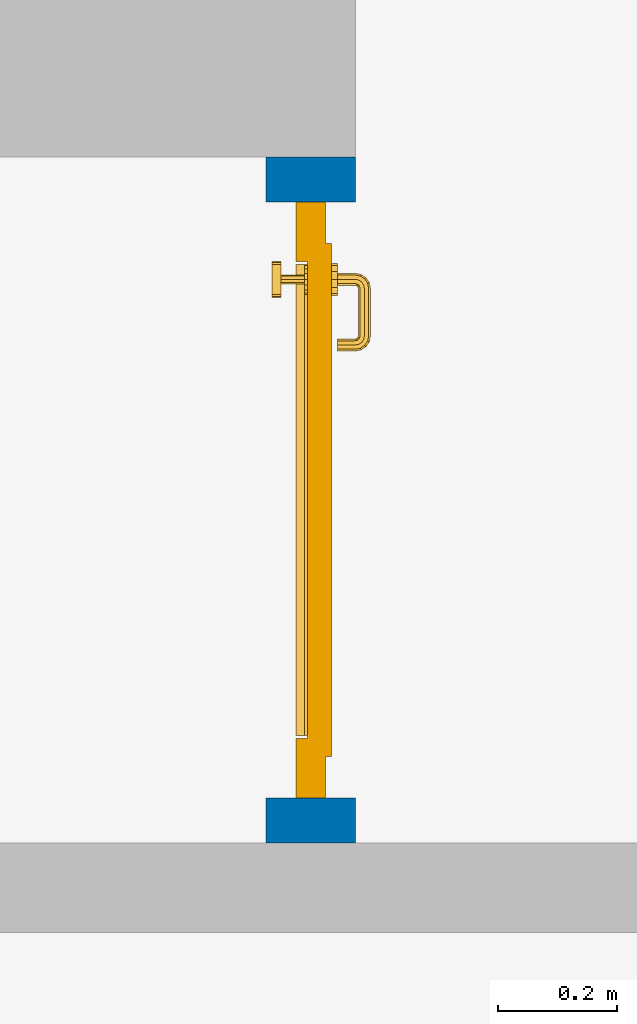
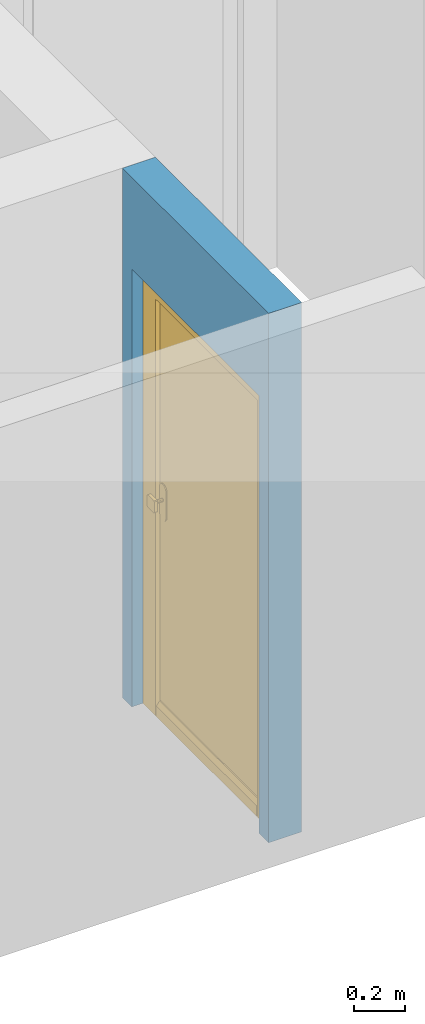
# One storey, part 4 of 54: 1 door, 1 wall, 1 opening.
"""IFC4 building model written with IfcOpenShell, lengths in metres."""

from ifc_helpers import new_model, entity, si_unit, converted_unit, derived_unit, direction, frame, origin_with_axes, place, context, subcontext, project, spatial, polygons, source, transform, mapped, material, type_object, element, fill, save


model = new_model("IFC4")

# Units and contexts
model_context = context("Model", 3, precision=1e-05, world=origin_with_axes(), true_north=direction((0.0, 1.0)))
body_context = subcontext(model_context, "Body", "Model", "MODEL_VIEW")
ifc_project = project(units=[si_unit("LENGTHUNIT", "METRE"), si_unit("AREAUNIT", "SQUARE_METRE"), si_unit("VOLUMEUNIT", "CUBIC_METRE"), converted_unit("PLANEANGLEUNIT", "DEGREE", entity("IfcPlaneAngleMeasure", 0.0174532925199), si_unit("PLANEANGLEUNIT", "RADIAN"), dimensions=[0, 0, 0, 0, 0, 0, 0]), converted_unit("TIMEUNIT", "Year", entity("IfcTimeMeasure", 31556926.0), si_unit("TIMEUNIT", "SECOND"), dimensions=[0, 0, 1, 0, 0, 0, 0]), si_unit("MASSUNIT", "GRAM", prefix="KILO"), si_unit("THERMODYNAMICTEMPERATUREUNIT", "DEGREE_CELSIUS"), si_unit("LUMINOUSINTENSITYUNIT", "LUMEN"), si_unit("ENERGYUNIT", "JOULE", prefix="MEGA"), derived_unit("THERMALCONDUCTANCEUNIT", [(si_unit("POWERUNIT", "WATT"), 1), (si_unit("LENGTHUNIT", "METRE"), -1), (si_unit("THERMODYNAMICTEMPERATUREUNIT", "KELVIN"), -1)]), derived_unit("SPECIFICHEATCAPACITYUNIT", [(si_unit("ENERGYUNIT", "JOULE"), 1), (si_unit("MASSUNIT", "GRAM", prefix="KILO"), -1), (si_unit("THERMODYNAMICTEMPERATUREUNIT", "KELVIN"), -1)]), derived_unit("MASSDENSITYUNIT", [(si_unit("MASSUNIT", "GRAM", prefix="KILO"), 1), (si_unit("VOLUMEUNIT", "CUBIC_METRE"), -1)])], contexts=[model_context])

# Site, building, storey
site_placement = place(None, origin_with_axes())
site = spatial("IfcSite", under=ifc_project, at=site_placement, CompositionType="ELEMENT")
building_placement = place(site_placement, origin_with_axes())
building = spatial("IfcBuilding", under=site, at=building_placement, CompositionType="ELEMENT")
storey_placement = place(building_placement, frame((0.0, 0.0, 6.29), z_axis=(0.0, 0.0, 1.0), x_axis=(1.0, 0.0, 0.0)))
storey = spatial("IfcBuildingStorey", under=building, at=storey_placement, Name="2. Geschoss", CompositionType="ELEMENT", Elevation=6.29)

# Wall, opening, door
ifc_material = material()
wall_type = type_object("IfcWallType", Name="150", PredefinedType="NOTDEFINED")
wall_placement = place(storey_placement, frame((2.8378006196, -4.12881223104, 0.0), z_axis=(0.0, 0.0, 1.0), x_axis=(0.0, 1.0, 0.0)))
wall = element("IfcWall", 1, at=wall_placement, inside=storey, type_object=wall_type, material=ifc_material, Name="Wand-002", PredefinedType="NOTDEFINED", context=body_context, shape_type="Tessellation", body=[
    polygons([(0.225, 0.0, 0.0), (0.225, 0.0, 2.1), (1.225, 0.0, 2.1), (1.225, 0.0, 0.0), (1.3, 0.0, 0.0), (1.3, 0.0, 2.54), (0.15, 0.0, 2.54), (0.15, 0.0, 0.0), (0.225, 0.1, 0.0), (0.225, 0.15, 0.0), (0.225, 0.15, 2.1), (1.225, 0.15, 2.1), (1.225, 0.1, 0.0), (1.225, 0.15, 0.0), (1.3, 0.15, 0.0), (1.3, 0.15, 2.54), (0.15, 0.15, 2.54), (0.15, 0.15, 0.0)], [[[1, 2, 3, 4, 5, 6, 7, 8]], [[2, 1, 9, 10, 11]], [[3, 2, 11, 12]], [[13, 4, 3, 12, 14]], [[4, 13, 14, 15, 5]], [[6, 5, 15, 16]], [[6, 16, 17, 7]], [[17, 18, 8, 7]], [[9, 1, 8, 18, 10]], [[15, 14, 12, 11, 10, 18, 17, 16]]], closed=True),
])
opening_placement = place(wall_placement, frame((0.725, 0.0, 0.0), z_axis=(0.0, 0.0, 1.0), x_axis=(1.0, 0.0, 0.0)))
opening = element("IfcOpeningElement", 2, at=opening_placement, cuts=wall, context=body_context, identifier="Reference", shape_type="Tessellation", body=[
    polygons([(-0.5, 0.1, 0.0), (-0.5, 0.1, 2.1), (-0.5, 0.151, 2.1), (-0.5, 0.151, 0.0), (-0.5, -0.001, 0.0), (-0.5, -0.001, 2.1), (0.5, 0.1, 2.1), (0.5, 0.151, 2.1), (0.5, -0.001, 2.1), (0.5, 0.151, 0.0), (0.5, 0.1, 0.0), (0.5, -0.001, 0.0)], [[[1, 2, 3, 4]], [[2, 1, 5, 6]], [[7, 8, 3, 2, 6, 9]], [[8, 10, 4, 3]], [[1, 4, 10, 11, 12, 5]], [[6, 5, 12, 9]], [[7, 11, 10, 8]], [[11, 7, 9, 12]]], closed=True),
])
door_type = type_object("IfcDoorType", Name="Eingang 01 1-Fl 26", OperationType="SINGLE_SWING_RIGHT", PredefinedType="DOOR")
shared_shape = source(origin_with_axes(), body_context, "Body", "Tessellation", [
    polygons([(0.5, -0.05, 0.0), (0.5, -0.03, 0.0), (0.5, -0.03, 2.1), (0.5, -0.05, 2.1), (0.4, -0.05, 0.0), (0.4, -0.03, 0.0), (0.4, -0.03, 2.0), (0.1301, -0.03, 2.0), (0.0001, -0.03, 2.0), (-0.4, -0.03, 2.0), (-0.4, -0.03, 0.0), (-0.5, -0.03, 0.0), (-0.5, -0.03, 2.1), (-0.5, -0.05, 2.1), (-0.5, -0.05, 0.0), (-0.4, -0.05, 0.0), (-0.4, -0.05, 2.0), (0.0001, -0.05, 2.0), (0.1301, -0.05, 2.0), (0.4, -0.05, 2.0)], [[[1, 2, 3, 4]], [[5, 6, 2, 1]], [[2, 6, 7, 8, 9, 10, 11, 12, 13, 3]], [[4, 3, 13, 14]], [[1, 4, 14, 15, 16, 17, 18, 19, 20, 5]], [[20, 7, 6, 5]], [[19, 8, 7, 20]], [[18, 9, 8, 19]], [[17, 10, 9, 18]], [[16, 11, 10, 17]], [[15, 12, 11, 16]], [[14, 13, 12, 15]]], closed=True),
    polygons([(0.5, -0.03, 0.0), (0.5, 0.0, 0.0), (0.5, 0.0, 2.1), (0.5, -0.03, 2.1), (0.43, -0.03, 0.0), (0.43, 0.0, 0.0), (0.43, 0.0, 2.03), (0.1001, 0.0, 2.03), (0.0301, 0.0, 2.03), (-0.43, 0.0, 2.03), (-0.43, 0.0, 0.0), (-0.5, 0.0, 0.0), (-0.5, 0.0, 2.1), (-0.5, -0.03, 2.1), (-0.5, -0.03, 0.0), (-0.43, -0.03, 0.0), (-0.43, -0.03, 2.03), (0.0301, -0.03, 2.03), (0.1001, -0.03, 2.03), (0.43, -0.03, 2.03)], [[[1, 2, 3, 4]], [[5, 6, 2, 1]], [[2, 6, 7, 8, 9, 10, 11, 12, 13, 3]], [[4, 3, 13, 14]], [[1, 4, 14, 15, 16, 17, 18, 19, 20, 5]], [[20, 7, 6, 5]], [[19, 8, 7, 20]], [[18, 9, 8, 19]], [[17, 10, 9, 18]], [[16, 11, 10, 17]], [[15, 12, 11, 16]], [[14, 13, 12, 15]]], closed=True),
    polygons([(0.43, 0.01, 0.0), (-0.43, 0.01, 0.0), (-0.43, 0.01, 2.03), (0.43, 0.01, 2.03), (0.43, -0.03, 0.0), (-0.43, -0.03, 0.0), (-0.43, -0.03, 2.03), (0.43, -0.03, 2.03)], [[[1, 2, 3, 4]], [[2, 1, 5, 6]], [[3, 2, 6, 7]], [[4, 3, 7, 8]], [[1, 4, 8, 5]], [[6, 5, 8, 7]]], closed=True),
    polygons([(0.395, -0.05, 0.0), (0.395, -0.05, 0.05), (-0.395, -0.05, 0.05), (-0.395, -0.05, 0.0), (0.395, -0.03, 0.0), (0.395, -0.03, 0.07), (0.395, -0.035, 0.07), (-0.395, -0.035, 0.07), (-0.395, -0.03, 0.07), (-0.395, -0.03, 0.0)], [[[1, 2, 3, 4]], [[1, 5, 6, 7, 2]], [[2, 7, 8, 3]], [[4, 3, 8, 9, 10]], [[5, 1, 4, 10]], [[6, 5, 10, 9]], [[7, 6, 9, 8]]], closed=True),
    polygons([(-0.3835, 0.02, 1.0733826859), (-0.3835, 0.0199, 1.0733826859), (-0.37, 0.0199, 1.077), (-0.37, 0.02, 1.077), (-0.393382685902, 0.02, 1.0635), (-0.393382685902, 0.0199, 1.0635), (-0.3835, 0.0101, 1.0733826859), (-0.37, 0.0101, 1.077), (-0.3565, 0.0199, 1.0733826859), (-0.3565, 0.02, 1.0733826859), (-0.346617314098, 0.02, 1.0635), (-0.343, 0.02, 1.05), (-0.346617314098, 0.02, 1.0365), (-0.3565, 0.02, 1.0266173141), (-0.37, 0.02, 1.023), (-0.3835, 0.02, 1.0266173141), (-0.393382685902, 0.02, 1.0365), (-0.397, 0.02, 1.05), (-0.397, 0.0199, 1.05), (-0.393382685902, 0.0101, 1.0635), (-0.3835, 0.01, 1.0733826859), (-0.37, 0.01, 1.077), (-0.3565, 0.0101, 1.0733826859), (-0.346617314098, 0.0199, 1.0635), (-0.343, 0.0199, 1.05), (-0.346617314098, 0.0199, 1.0365), (-0.3565, 0.0199, 1.0266173141), (-0.37, 0.0199, 1.023), (-0.3835, 0.0199, 1.0266173141), (-0.393382685902, 0.0199, 1.0365), (-0.397, 0.0101, 1.05), (-0.393382685902, 0.01, 1.0635), (-0.397, 0.01, 1.05), (-0.393382685902, 0.01, 1.0365), (-0.3835, 0.01, 1.0266173141), (-0.37, 0.01, 1.023), (-0.3565, 0.01, 1.0266173141), (-0.346617314098, 0.01, 1.0365), (-0.343, 0.01, 1.05), (-0.346617314098, 0.01, 1.0635), (-0.3565, 0.01, 1.0733826859), (-0.346617314098, 0.0101, 1.0635), (-0.343, 0.0101, 1.05), (-0.346617314098, 0.0101, 1.0365), (-0.3565, 0.0101, 1.0266173141), (-0.37, 0.0101, 1.023), (-0.3835, 0.0101, 1.0266173141), (-0.393382685902, 0.0101, 1.0365)], [[[1, 2, 3, 4]], [[5, 6, 2, 1]], [[2, 7, 8, 3]], [[4, 3, 9, 10]], [[4, 10, 11, 12, 13, 14, 15, 16, 17, 18, 5, 1]], [[18, 19, 6, 5]], [[6, 20, 7, 2]], [[7, 21, 22, 8]], [[3, 8, 23, 9]], [[10, 9, 24, 11]], [[11, 24, 25, 12]], [[12, 25, 26, 13]], [[13, 26, 27, 14]], [[14, 27, 28, 15]], [[15, 28, 29, 16]], [[16, 29, 30, 17]], [[17, 30, 19, 18]], [[19, 31, 20, 6]], [[20, 32, 21, 7]], [[22, 21, 32, 33, 34, 35, 36, 37, 38, 39, 40, 41]], [[8, 22, 41, 23]], [[9, 23, 42, 24]], [[24, 42, 43, 25]], [[25, 43, 44, 26]], [[26, 44, 45, 27]], [[27, 45, 46, 28]], [[28, 46, 47, 29]], [[29, 47, 48, 30]], [[30, 48, 31, 19]], [[31, 33, 32, 20]], [[48, 34, 33, 31]], [[47, 35, 34, 48]], [[46, 36, 35, 47]], [[45, 37, 36, 46]], [[44, 38, 37, 45]], [[43, 39, 38, 44]], [[42, 40, 39, 43]], [[23, 41, 40, 42]]], closed=True),
    polygons([(-0.362532169224, 0.019, 0.959692280177), (-0.365, 0.019, 0.9544), (-0.365, 0.019, 0.952886751346), (-0.347569942042, 0.019, 0.96295), (-0.35705, 0.019, 0.972430057958), (-0.363279754556, 0.019, 0.961639806549), (-0.362532169224, 0.02, 0.959692280177), (-0.365, 0.02, 0.9544), (-0.365, 0.02, 0.952886751346), (-0.365, 0.02, 0.95), (-0.365, 0.02, 0.947113248654), (-0.365, 0.02, 0.941339745962), (-0.365, 0.02, 0.9375), (-0.365, 0.019, 0.9375), (-0.365, 0.019, 0.941339745962), (-0.365, 0.019, 0.947113248654), (-0.365, 0.019, 0.95), (-0.3441, 0.019, 0.95), (-0.347483339502, 0.019, 0.963), (-0.357, 0.019, 0.972516660498), (-0.364624817685, 0.019, 0.965143815798), (-0.37, 0.019, 0.9759), (-0.37, 0.019, 0.967425445323), (-0.364624817685, 0.02, 0.965143815798), (-0.363279754556, 0.02, 0.961639806549), (-0.35655, 0.02, 0.973296083362), (-0.346703916638, 0.02, 0.96345), (-0.3431, 0.02, 0.95), (-0.346703916638, 0.02, 0.93655), (-0.35655, 0.02, 0.926703916638), (-0.37, 0.02, 0.9231), (-0.37, 0.02, 0.9325), (-0.366464466094, 0.02, 0.933964466094), (-0.366464466094, 0.019, 0.933964466094), (-0.35705, 0.019, 0.927569942042), (-0.37, 0.019, 0.9325), (-0.37, 0.019, 0.9241), (-0.347569942042, 0.019, 0.93705), (-0.344, 0.019, 0.95), (-0.347483339502, 0.0189, 0.963), (-0.357, 0.0189, 0.972516660498), (-0.37, 0.019, 0.976), (-0.375375182315, 0.019, 0.965143815798), (-0.38295, 0.019, 0.972430057958), (-0.376720245444, 0.019, 0.961639806549), (-0.37, 0.02, 0.967425445323), (-0.37, 0.02, 0.9769), (-0.346617314098, 0.02, 0.9635), (-0.3565, 0.02, 0.973382685902), (-0.343, 0.02, 0.95), (-0.346617314098, 0.02, 0.9365), (-0.3565, 0.02, 0.926617314098), (-0.38345, 0.02, 0.926703916638), (-0.375, 0.02, 0.941339745962), (-0.375, 0.02, 0.9375), (-0.373535533906, 0.02, 0.933964466094), (-0.37, 0.02, 0.923), (-0.373535533906, 0.019, 0.933964466094), (-0.375, 0.019, 0.9375), (-0.375, 0.019, 0.941339745962), (-0.38295, 0.019, 0.927569942042), (-0.37, 0.019, 0.924), (-0.357, 0.019, 0.927483339502), (-0.347483339502, 0.019, 0.937), (-0.344, 0.0189, 0.95), (-0.347483339502, 0.0101, 0.963), (-0.357, 0.0101, 0.972516660498), (-0.37, 0.0189, 0.976), (-0.383, 0.019, 0.972516660498), (-0.375375182315, 0.02, 0.965143815798), (-0.377467830776, 0.019, 0.959692280177), (-0.392430057958, 0.019, 0.96295), (-0.375, 0.019, 0.952886751346), (-0.375, 0.019, 0.9544), (-0.377467830776, 0.02, 0.959692280177), (-0.376720245444, 0.02, 0.961639806549), (-0.38345, 0.02, 0.973296083362), (-0.37, 0.02, 0.977), (-0.346617314098, 0.0199, 0.9635), (-0.3565, 0.0199, 0.973382685902), (-0.343, 0.0199, 0.95), (-0.346617314098, 0.0199, 0.9365), (-0.3565, 0.0199, 0.926617314098), (-0.393296083362, 0.02, 0.93655), (-0.375, 0.02, 0.947113248654), (-0.375, 0.02, 0.9544), (-0.375, 0.019, 0.95), (-0.375, 0.019, 0.947113248654), (-0.375, 0.02, 0.95), (-0.375, 0.02, 0.952886751346), (-0.3835, 0.02, 0.926617314098), (-0.37, 0.0199, 0.923), (-0.392430057958, 0.019, 0.93705), (-0.383, 0.019, 0.927483339502), (-0.37, 0.0189, 0.924), (-0.357, 0.0189, 0.927483339502), (-0.347483339502, 0.0189, 0.937), (-0.344, 0.0101, 0.95), (-0.347483339502, 0.01, 0.963), (-0.357, 0.01, 0.972516660498), (-0.37, 0.0101, 0.976), (-0.383, 0.0189, 0.972516660498), (-0.392516660498, 0.019, 0.963), (-0.3959, 0.019, 0.95), (-0.393296083362, 0.02, 0.96345), (-0.3835, 0.02, 0.973382685902), (-0.37, 0.0199, 0.977), (-0.346617314098, 0.0101, 0.9635), (-0.3565, 0.0101, 0.973382685902), (-0.343, 0.0101, 0.95), (-0.346617314098, 0.0101, 0.9365), (-0.3565, 0.0101, 0.926617314098), (-0.393382685902, 0.02, 0.9365), (-0.3969, 0.02, 0.95), (-0.3835, 0.0199, 0.926617314098), (-0.37, 0.0101, 0.923), (-0.392516660498, 0.019, 0.937), (-0.383, 0.0189, 0.927483339502), (-0.37, 0.0101, 0.924), (-0.357, 0.0101, 0.927483339502), (-0.347483339502, 0.0101, 0.937), (-0.344, 0.01, 0.95), (-0.347396736961, 0.01, 0.96305), (-0.35695, 0.01, 0.972603263039), (-0.37, 0.01, 0.976), (-0.383, 0.0101, 0.972516660498), (-0.392516660498, 0.0189, 0.963), (-0.396, 0.019, 0.95), (-0.393382685902, 0.02, 0.9635), (-0.3835, 0.0199, 0.973382685902), (-0.37, 0.0101, 0.977), (-0.346617314098, 0.01, 0.9635), (-0.3565, 0.01, 0.973382685902), (-0.343, 0.01, 0.95), (-0.346617314098, 0.01, 0.9365), (-0.3565, 0.01, 0.926617314098), (-0.397, 0.02, 0.95), (-0.393382685902, 0.0199, 0.9365), (-0.3835, 0.0101, 0.926617314098), (-0.37, 0.01, 0.923), (-0.392516660498, 0.0189, 0.937), (-0.383, 0.0101, 0.927483339502), (-0.37, 0.01, 0.924), (-0.357, 0.01, 0.927483339502), (-0.347483339502, 0.01, 0.937), (-0.3439, 0.01, 0.95), (-0.346703916638, 0.01, 0.96345), (-0.35655, 0.01, 0.973296083362), (-0.37, 0.01, 0.9761), (-0.383, 0.01, 0.972516660498), (-0.392516660498, 0.0101, 0.963), (-0.396, 0.0189, 0.95), (-0.393382685902, 0.0199, 0.9635), (-0.3835, 0.0101, 0.973382685902), (-0.37, 0.01, 0.977), (-0.3431, 0.01, 0.95), (-0.346703916638, 0.01, 0.93655), (-0.35655, 0.01, 0.926703916638), (-0.397, 0.0199, 0.95), (-0.393382685902, 0.0101, 0.9365), (-0.3835, 0.01, 0.926617314098), (-0.37, 0.01, 0.9231), (-0.392516660498, 0.0101, 0.937), (-0.383, 0.01, 0.927483339502), (-0.37, 0.01, 0.9239), (-0.35695, 0.01, 0.927396736961), (-0.347396736961, 0.01, 0.93695), (-0.37, 0.01, 0.9769), (-0.38305, 0.01, 0.972603263039), (-0.392516660498, 0.01, 0.963), (-0.396, 0.0101, 0.95), (-0.393382685902, 0.0101, 0.9635), (-0.3835, 0.01, 0.973382685902), (-0.397, 0.0101, 0.95), (-0.393382685902, 0.01, 0.9365), (-0.38345, 0.01, 0.926703916638), (-0.392516660498, 0.01, 0.937), (-0.38305, 0.01, 0.927396736961), (-0.38345, 0.01, 0.973296083362), (-0.392603263039, 0.01, 0.96305), (-0.396, 0.01, 0.95), (-0.393382685902, 0.01, 0.9635), (-0.397, 0.01, 0.95), (-0.393296083362, 0.01, 0.93655), (-0.392603263039, 0.01, 0.93695), (-0.393296083362, 0.01, 0.96345), (-0.3961, 0.01, 0.95), (-0.3969, 0.01, 0.95)], [[[1, 2, 3, 4, 5, 6]], [[2, 1, 7, 8]], [[2, 8, 9, 10, 11, 12, 13, 14, 15, 16, 17, 3]], [[17, 18, 4, 3]], [[4, 19, 20, 5]], [[21, 6, 5, 22, 23]], [[1, 6, 21, 24, 25, 7]], [[7, 25, 26, 27, 9, 8]], [[9, 27, 28, 10]], [[10, 28, 29, 11]], [[11, 29, 30, 12]], [[31, 32, 33, 13, 12, 30]], [[14, 13, 33, 34]], [[35, 15, 14, 34, 36, 37]], [[15, 35, 38, 16]], [[16, 38, 18, 17]], [[18, 39, 19, 4]], [[19, 40, 41, 20]], [[5, 20, 42, 22]], [[43, 23, 22, 44, 45]], [[21, 23, 46, 24]], [[24, 46, 47, 26, 25]], [[48, 27, 26, 49]], [[50, 28, 27, 48]], [[51, 29, 28, 50]], [[52, 30, 29, 51]], [[53, 54, 55, 56, 32, 31]], [[34, 33, 32, 36]], [[57, 31, 30, 52]], [[37, 36, 58, 59, 60, 61]], [[37, 62, 63, 35]], [[35, 63, 64, 38]], [[38, 64, 39, 18]], [[39, 65, 40, 19]], [[40, 66, 67, 41]], [[20, 41, 68, 42]], [[22, 42, 69, 44]], [[23, 43, 70, 46]], [[71, 45, 44, 72, 73, 74]], [[43, 45, 71, 75, 76, 70]], [[70, 76, 77, 47, 46]], [[49, 26, 47, 78]], [[79, 48, 49, 80]], [[81, 50, 48, 79]], [[82, 51, 50, 81]], [[83, 52, 51, 82]], [[54, 53, 84, 85]], [[86, 74, 73, 87, 88, 60, 59, 55, 54, 85, 89, 90]], [[58, 56, 55, 59]], [[36, 32, 56, 58]], [[91, 53, 31, 57]], [[92, 57, 52, 83]], [[88, 93, 61, 60]], [[61, 94, 62, 37]], [[62, 95, 96, 63]], [[63, 96, 97, 64]], [[64, 97, 65, 39]], [[65, 98, 66, 40]], [[66, 99, 100, 67]], [[41, 67, 101, 68]], [[42, 68, 102, 69]], [[44, 69, 103, 72]], [[73, 72, 104, 87]], [[71, 74, 86, 75]], [[75, 86, 90, 105, 77, 76]], [[78, 47, 77, 106]], [[80, 49, 78, 107]], [[108, 79, 80, 109]], [[110, 81, 79, 108]], [[111, 82, 81, 110]], [[112, 83, 82, 111]], [[113, 84, 53, 91]], [[85, 84, 114, 89]], [[87, 104, 93, 88]], [[89, 114, 105, 90]], [[115, 91, 57, 92]], [[116, 92, 83, 112]], [[93, 117, 94, 61]], [[94, 118, 95, 62]], [[95, 119, 120, 96]], [[96, 120, 121, 97]], [[97, 121, 98, 65]], [[98, 122, 99, 66]], [[99, 123, 124, 100]], [[67, 100, 125, 101]], [[68, 101, 126, 102]], [[69, 102, 127, 103]], [[72, 103, 128, 104]], [[106, 77, 105, 129]], [[107, 78, 106, 130]], [[109, 80, 107, 131]], [[132, 108, 109, 133]], [[134, 110, 108, 132]], [[135, 111, 110, 134]], [[136, 112, 111, 135]], [[137, 114, 84, 113]], [[138, 113, 91, 115]], [[104, 128, 117, 93]], [[129, 105, 114, 137]], [[139, 115, 92, 116]], [[140, 116, 112, 136]], [[117, 141, 118, 94]], [[118, 142, 119, 95]], [[119, 143, 144, 120]], [[120, 144, 145, 121]], [[121, 145, 122, 98]], [[122, 146, 123, 99]], [[123, 147, 148, 124]], [[100, 124, 149, 125]], [[101, 125, 150, 126]], [[102, 126, 151, 127]], [[103, 127, 152, 128]], [[130, 106, 129, 153]], [[131, 107, 130, 154]], [[133, 109, 131, 155]], [[147, 132, 133, 148]], [[156, 134, 132, 147]], [[157, 135, 134, 156]], [[158, 136, 135, 157]], [[159, 137, 113, 138]], [[160, 138, 115, 139]], [[128, 152, 141, 117]], [[153, 129, 137, 159]], [[161, 139, 116, 140]], [[162, 140, 136, 158]], [[141, 163, 142, 118]], [[142, 164, 143, 119]], [[143, 165, 166, 144]], [[144, 166, 167, 145]], [[145, 167, 146, 122]], [[146, 156, 147, 123]], [[124, 148, 168, 149]], [[125, 149, 169, 150]], [[126, 150, 170, 151]], [[127, 151, 171, 152]], [[154, 130, 153, 172]], [[155, 131, 154, 173]], [[148, 133, 155, 168]], [[167, 157, 156, 146]], [[166, 158, 157, 167]], [[174, 159, 138, 160]], [[175, 160, 139, 161]], [[152, 171, 163, 141]], [[172, 153, 159, 174]], [[176, 161, 140, 162]], [[165, 162, 158, 166]], [[163, 177, 164, 142]], [[164, 178, 165, 143]], [[149, 168, 179, 169]], [[150, 169, 180, 170]], [[151, 170, 181, 171]], [[173, 154, 172, 182]], [[168, 155, 173, 179]], [[183, 174, 160, 175]], [[184, 175, 161, 176]], [[171, 181, 177, 163]], [[182, 172, 174, 183]], [[178, 176, 162, 165]], [[177, 185, 178, 164]], [[169, 179, 186, 180]], [[170, 180, 187, 181]], [[179, 173, 182, 186]], [[188, 183, 175, 184]], [[185, 184, 176, 178]], [[181, 187, 185, 177]], [[186, 182, 183, 188]], [[180, 186, 188, 187]], [[187, 188, 184, 185]]], closed=True),
    polygons([(-0.38, 0.02, 1.05), (-0.38, 0.0509849140336, 1.05), (-0.377071067812, 0.050696439392, 1.04292893219), (-0.377071067812, 0.02, 1.04292893219), (-0.377071067812, 0.02, 1.05707106781), (-0.377071067812, 0.050696439392, 1.05707106781), (-0.378277987014, 0.0596420579258, 1.05), (-0.375518993221, 0.0584992452783, 1.04292893219), (-0.37, 0.05, 1.04), (-0.37, 0.02, 1.04), (-0.37, 0.02, 1.06), (-0.37, 0.05, 1.06), (-0.375518993221, 0.0584992452783, 1.05707106781), (-0.372816199938, 0.0678161999379, 1.05), (-0.370704557509, 0.0657045575088, 1.04292893219), (-0.368858192988, 0.0557402514855, 1.04), (-0.362928932188, 0.049303560608, 1.04292893219), (-0.362928932188, 0.02, 1.04292893219), (-0.362928932188, 0.02, 1.05707106781), (-0.362928932188, 0.049303560608, 1.05707106781), (-0.368858192988, 0.0557402514855, 1.06), (-0.370704557509, 0.0657045575088, 1.05707106781), (-0.364642057926, 0.0732779870137, 1.05), (-0.363499245278, 0.0705189932208, 1.04292893219), (-0.365606601718, 0.0606066017178, 1.04), (-0.362197392755, 0.0529812576926, 1.04292893219), (-0.36, 0.0490150859664, 1.05), (-0.36, 0.02, 1.05), (-0.362197392755, 0.0529812576926, 1.05707106781), (-0.365606601718, 0.0606066017178, 1.06), (-0.363499245278, 0.0705189932208, 1.05707106781), (-0.355984914034, 0.075, 1.05), (-0.355696439392, 0.0720710678119, 1.04292893219), (-0.360740251485, 0.0638581929877, 1.04), (-0.360508645927, 0.0555086459268, 1.04292893219), (-0.359438398962, 0.0518384450452, 1.05), (-0.360508645927, 0.0555086459268, 1.05707106781), (-0.360740251485, 0.0638581929877, 1.06), (-0.355696439392, 0.0720710678119, 1.05707106781), (-0.274015085966, 0.075, 1.05), (-0.274303560608, 0.0720710678119, 1.04292893219), (-0.355, 0.065, 1.04), (-0.357981257693, 0.0571973927545, 1.04292893219), (-0.358397003498, 0.0533970034977, 1.05), (-0.357981257693, 0.0571973927545, 1.05707106781), (-0.355, 0.065, 1.06), (-0.274303560608, 0.0720710678119, 1.05707106781), (-0.265357942074, 0.0732779870137, 1.05), (-0.266500754722, 0.0705189932208, 1.04292893219), (-0.275, 0.065, 1.04), (-0.354303560608, 0.0579289321881, 1.04292893219), (-0.356838445045, 0.0544383989617, 1.05), (-0.354303560608, 0.0579289321881, 1.05707106781), (-0.275, 0.065, 1.06), (-0.266500754722, 0.0705189932208, 1.05707106781), (-0.257183800062, 0.0678161999379, 1.05), (-0.259295442491, 0.0657045575088, 1.04292893219), (-0.269259748515, 0.0638581929877, 1.04), (-0.275696439392, 0.0579289321881, 1.04292893219), (-0.354015085966, 0.055, 1.05), (-0.275696439392, 0.0579289321881, 1.05707106781), (-0.269259748515, 0.0638581929877, 1.06), (-0.259295442491, 0.0657045575088, 1.05707106781), (-0.251722012986, 0.0596420579258, 1.05), (-0.254481006779, 0.0584992452783, 1.04292893219), (-0.264393398282, 0.0606066017178, 1.04), (-0.272018742307, 0.0571973927545, 1.04292893219), (-0.275984914034, 0.055, 1.05), (-0.272018742307, 0.0571973927545, 1.05707106781), (-0.264393398282, 0.0606066017178, 1.06), (-0.254481006779, 0.0584992452783, 1.05707106781), (-0.25, 0.0509849140336, 1.05), (-0.252928932188, 0.050696439392, 1.04292893219), (-0.261141807012, 0.0557402514855, 1.04), (-0.269491354073, 0.0555086459268, 1.04292893219), (-0.273161554955, 0.0544383989617, 1.05), (-0.269491354073, 0.0555086459268, 1.05707106781), (-0.261141807012, 0.0557402514855, 1.06), (-0.252928932188, 0.050696439392, 1.05707106781), (-0.25, 0.02, 1.05), (-0.252928932188, 0.02, 1.04292893219), (-0.26, 0.05, 1.04), (-0.267802607245, 0.0529812576926, 1.04292893219), (-0.271602996502, 0.0533970034977, 1.05), (-0.267802607245, 0.0529812576926, 1.05707106781), (-0.26, 0.05, 1.06), (-0.252928932188, 0.02, 1.05707106781), (-0.26, 0.02, 1.06), (-0.267071067812, 0.02, 1.05707106781), (-0.27, 0.02, 1.05), (-0.267071067812, 0.02, 1.04292893219), (-0.26, 0.02, 1.04), (-0.267071067812, 0.049303560608, 1.04292893219), (-0.270561601038, 0.0518384450452, 1.05), (-0.267071067812, 0.049303560608, 1.05707106781), (-0.27, 0.0490150859664, 1.05)], [[[1, 2, 3, 4]], [[5, 6, 2, 1]], [[2, 7, 8, 3]], [[4, 3, 9, 10]], [[11, 12, 6, 5]], [[6, 13, 7, 2]], [[7, 14, 15, 8]], [[3, 8, 16, 9]], [[10, 9, 17, 18]], [[19, 20, 12, 11]], [[12, 21, 13, 6]], [[13, 22, 14, 7]], [[14, 23, 24, 15]], [[8, 15, 25, 16]], [[9, 16, 26, 17]], [[18, 17, 27, 28]], [[28, 27, 20, 19]], [[20, 29, 21, 12]], [[21, 30, 22, 13]], [[22, 31, 23, 14]], [[23, 32, 33, 24]], [[15, 24, 34, 25]], [[16, 25, 35, 26]], [[17, 26, 36, 27]], [[27, 36, 29, 20]], [[29, 37, 30, 21]], [[30, 38, 31, 22]], [[31, 39, 32, 23]], [[32, 40, 41, 33]], [[24, 33, 42, 34]], [[25, 34, 43, 35]], [[26, 35, 44, 36]], [[36, 44, 37, 29]], [[37, 45, 38, 30]], [[38, 46, 39, 31]], [[39, 47, 40, 32]], [[40, 48, 49, 41]], [[33, 41, 50, 42]], [[34, 42, 51, 43]], [[35, 43, 52, 44]], [[44, 52, 45, 37]], [[45, 53, 46, 38]], [[46, 54, 47, 39]], [[47, 55, 48, 40]], [[48, 56, 57, 49]], [[41, 49, 58, 50]], [[42, 50, 59, 51]], [[43, 51, 60, 52]], [[52, 60, 53, 45]], [[53, 61, 54, 46]], [[54, 62, 55, 47]], [[55, 63, 56, 48]], [[56, 64, 65, 57]], [[49, 57, 66, 58]], [[50, 58, 67, 59]], [[51, 59, 68, 60]], [[60, 68, 61, 53]], [[61, 69, 62, 54]], [[62, 70, 63, 55]], [[63, 71, 64, 56]], [[64, 72, 73, 65]], [[57, 65, 74, 66]], [[58, 66, 75, 67]], [[59, 67, 76, 68]], [[68, 76, 69, 61]], [[69, 77, 70, 62]], [[70, 78, 71, 63]], [[71, 79, 72, 64]], [[72, 80, 81, 73]], [[65, 73, 82, 74]], [[66, 74, 83, 75]], [[67, 75, 84, 76]], [[76, 84, 77, 69]], [[77, 85, 78, 70]], [[78, 86, 79, 71]], [[79, 87, 80, 72]], [[80, 87, 88, 89, 90, 91, 92, 81]], [[73, 81, 92, 82]], [[74, 82, 93, 83]], [[75, 83, 94, 84]], [[84, 94, 85, 77]], [[85, 95, 86, 78]], [[86, 88, 87, 79]], [[95, 89, 88, 86]], [[96, 90, 89, 95]], [[93, 91, 90, 96]], [[82, 92, 91, 93]], [[83, 93, 96, 94]], [[94, 96, 95, 85]]], closed=False),
    polygons([(-0.364696699141, -0.035, 1.04469669914), (-0.37, -0.035, 1.0425), (-0.375303300859, -0.035, 1.04469669914), (-0.3775, -0.035, 1.05), (-0.375303300859, -0.035, 1.05530330086), (-0.37, -0.035, 1.0575), (-0.364696699141, -0.035, 1.05530330086), (-0.3625, -0.035, 1.05), (-0.364696699141, -0.075, 1.04469669914), (-0.37, -0.075, 1.0425), (-0.375303300859, -0.075, 1.04469669914), (-0.3775, -0.075, 1.05), (-0.375303300859, -0.075, 1.05530330086), (-0.37, -0.075, 1.0575), (-0.364696699141, -0.075, 1.05530330086), (-0.3625, -0.075, 1.05)], [[[1, 2, 3, 4, 5, 6, 7, 8]], [[2, 1, 9, 10]], [[3, 2, 10, 11]], [[4, 3, 11, 12]], [[5, 4, 12, 13]], [[6, 5, 13, 14]], [[7, 6, 14, 15]], [[8, 7, 15, 16]], [[1, 8, 16, 9]], [[9, 16, 15, 14, 13, 12, 11, 10]]], closed=True),
    polygons([(-0.395, -0.03, 0.975), (-0.393096988313, -0.03, 0.965432914191), (-0.393096988313, -0.035, 0.965432914191), (-0.395, -0.035, 0.975), (-0.395, -0.03, 1.1), (-0.393096988313, -0.03, 1.10956708581), (-0.38767766953, -0.03, 1.11767766953), (-0.379567085809, -0.03, 1.12309698831), (-0.37, -0.03, 1.125), (-0.360432914191, -0.03, 1.12309698831), (-0.35232233047, -0.03, 1.11767766953), (-0.346903011687, -0.03, 1.10956708581), (-0.345, -0.03, 1.1), (-0.345, -0.03, 0.975), (-0.346903011687, -0.03, 0.965432914191), (-0.35232233047, -0.03, 0.95732233047), (-0.360432914191, -0.03, 0.951903011687), (-0.37, -0.03, 0.95), (-0.379567085809, -0.03, 0.951903011687), (-0.38767766953, -0.03, 0.95732233047), (-0.38767766953, -0.035, 0.95732233047), (-0.379567085809, -0.035, 0.951903011687), (-0.37, -0.035, 0.95), (-0.360432914191, -0.035, 0.951903011687), (-0.35232233047, -0.035, 0.95732233047), (-0.346903011687, -0.035, 0.965432914191), (-0.345, -0.035, 0.975), (-0.345, -0.035, 1.1), (-0.346903011687, -0.035, 1.10956708581), (-0.35232233047, -0.035, 1.11767766953), (-0.360432914191, -0.035, 1.12309698831), (-0.37, -0.035, 1.125), (-0.379567085809, -0.035, 1.12309698831), (-0.38767766953, -0.035, 1.11767766953), (-0.393096988313, -0.035, 1.10956708581), (-0.395, -0.035, 1.1)], [[[1, 2, 3, 4]], [[1, 5, 6, 7, 8, 9, 10, 11, 12, 13, 14, 15, 16, 17, 18, 19, 20, 2]], [[2, 20, 21, 3]], [[4, 3, 21, 22, 23, 24, 25, 26, 27, 28, 29, 30, 31, 32, 33, 34, 35, 36]], [[5, 1, 4, 36]], [[6, 5, 36, 35]], [[7, 6, 35, 34]], [[8, 7, 34, 33]], [[9, 8, 33, 32]], [[10, 9, 32, 31]], [[11, 10, 31, 30]], [[12, 11, 30, 29]], [[13, 12, 29, 28]], [[14, 13, 28, 27]], [[15, 14, 27, 26]], [[16, 15, 26, 25]], [[17, 16, 25, 24]], [[18, 17, 24, 23]], [[19, 18, 23, 22]], [[20, 19, 22, 21]]], closed=True),
    polygons([(-0.39, -0.075, 1.08), (-0.395, -0.075, 1.07866025404), (-0.395, -0.09, 1.07866025404), (-0.39, -0.09, 1.08), (-0.35, -0.075, 1.08), (-0.345, -0.075, 1.07866025404), (-0.341339745962, -0.075, 1.075), (-0.34, -0.075, 1.07), (-0.34, -0.075, 1.03), (-0.341339745962, -0.075, 1.025), (-0.345, -0.075, 1.02133974596), (-0.35, -0.075, 1.02), (-0.39, -0.075, 1.02), (-0.395, -0.075, 1.02133974596), (-0.398660254038, -0.075, 1.025), (-0.4, -0.075, 1.03), (-0.4, -0.075, 1.07), (-0.398660254038, -0.075, 1.075), (-0.398660254038, -0.09, 1.075), (-0.4, -0.09, 1.07), (-0.4, -0.09, 1.03), (-0.398660254038, -0.09, 1.025), (-0.395, -0.09, 1.02133974596), (-0.39, -0.09, 1.02), (-0.35, -0.09, 1.02), (-0.345, -0.09, 1.02133974596), (-0.341339745962, -0.09, 1.025), (-0.34, -0.09, 1.03), (-0.34, -0.09, 1.07), (-0.341339745962, -0.09, 1.075), (-0.345, -0.09, 1.07866025404), (-0.35, -0.09, 1.08)], [[[1, 2, 3, 4]], [[1, 5, 6, 7, 8, 9, 10, 11, 12, 13, 14, 15, 16, 17, 18, 2]], [[2, 18, 19, 3]], [[4, 3, 19, 20, 21, 22, 23, 24, 25, 26, 27, 28, 29, 30, 31, 32]], [[5, 1, 4, 32]], [[6, 5, 32, 31]], [[7, 6, 31, 30]], [[8, 7, 30, 29]], [[9, 8, 29, 28]], [[10, 9, 28, 27]], [[11, 10, 27, 26]], [[12, 11, 26, 25]], [[13, 12, 25, 24]], [[14, 13, 24, 23]], [[15, 14, 23, 22]], [[16, 15, 22, 21]], [[17, 16, 21, 20]], [[18, 17, 20, 19]]], closed=True),
])
door_placement = place(opening_placement, frame((0.4, 0.0, 0.0), z_axis=(0.0, 0.0, 1.0), x_axis=(-1.0, 0.0, 0.0)))
door = element("IfcDoor", 3, at=door_placement, inside=storey, type_object=door_type, OverallHeight=2.1, OverallWidth=1.0, PredefinedType="DOOR", context=body_context, shape_type="MappedRepresentation", body=[
    mapped(shared_shape, transform((0.4, -0.05, 0.0))),
])
fill(opening, door)

save(model, "model.ifc")
